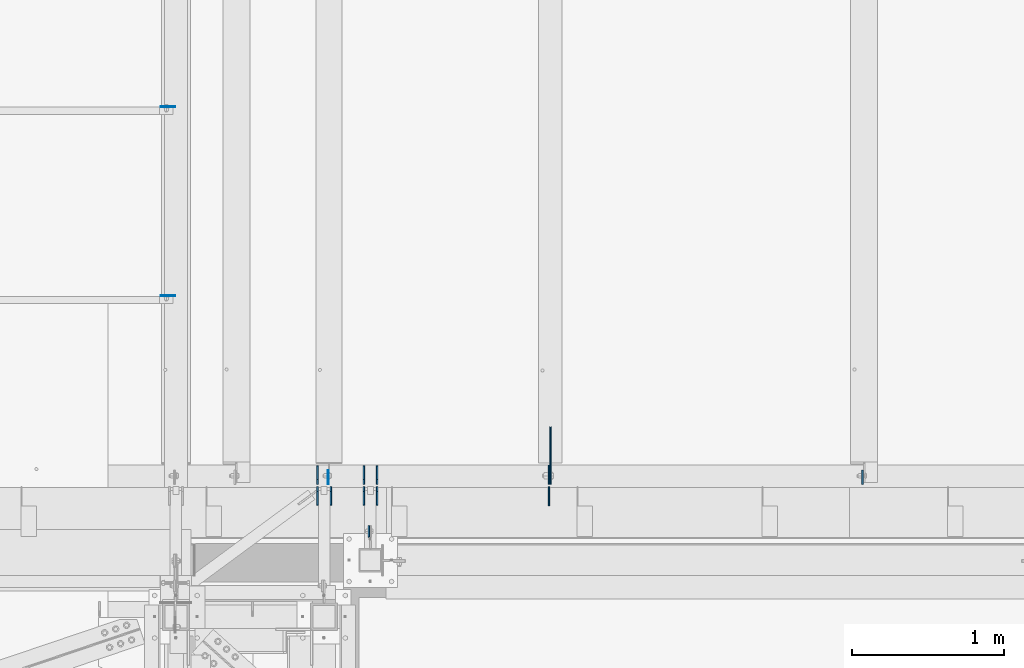
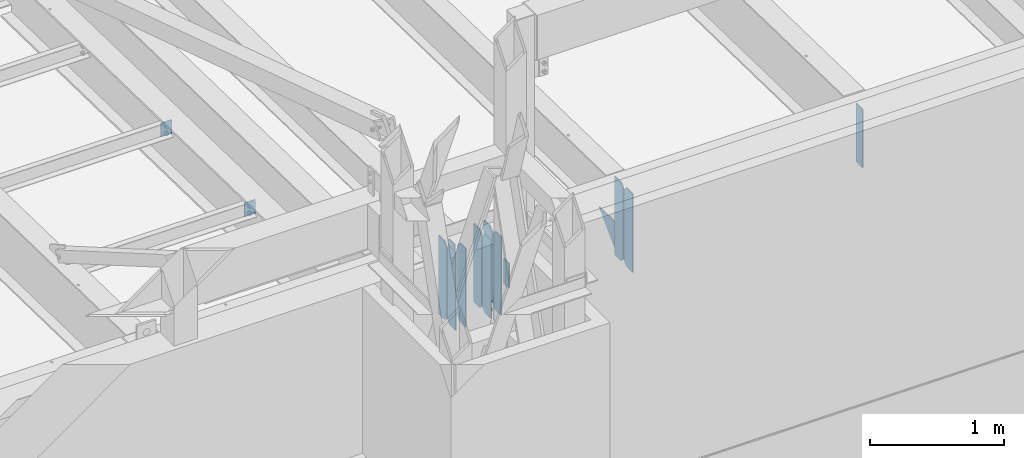
# One storey, part 1482 of 1763: 15 plates, 4 elements without a shape of their own.
"""IFC2X3 building model written with IfcOpenShell, lengths in millimetres."""

from ifc_helpers import new_model, si_unit, frame, origin_with_axes, place, context, subcontext, project, spatial, faceted_brep, material, type_object, element, aggregate, save


model = new_model("IFC2X3")

# Units and contexts
model_context = context("Model", 3, precision=1e-05, world=origin_with_axes())
body_context = subcontext(model_context, "Body", "Model", "MODEL_VIEW")
ifc_project = project(units=[si_unit("LENGTHUNIT", "METRE", prefix="MILLI"), si_unit("AREAUNIT", "SQUARE_METRE"), si_unit("VOLUMEUNIT", "CUBIC_METRE"), si_unit("MASSUNIT", "GRAM", prefix="KILO"), si_unit("TIMEUNIT", "SECOND"), si_unit("PLANEANGLEUNIT", "RADIAN"), si_unit("SOLIDANGLEUNIT", "STERADIAN"), si_unit("THERMODYNAMICTEMPERATUREUNIT", "DEGREE_CELSIUS"), si_unit("LUMINOUSINTENSITYUNIT", "LUMEN")], contexts=[model_context])

# Site, building, storey
site_placement = place(None, origin_with_axes())
site = spatial("IfcSite", under=ifc_project, at=site_placement, CompositionType="ELEMENT")
building_placement = place(site_placement, origin_with_axes())
building = spatial("IfcBuilding", under=site, at=building_placement, Name="Undefined", CompositionType="ELEMENT")
storey_placement = place(building_placement, origin_with_axes())
storey = spatial("IfcBuildingStorey", under=building, at=storey_placement, Name="Undefined", CompositionType="ELEMENT", Elevation=0.0)

# Assembly, plate
assembly_1_placement = place(storey_placement, origin_with_axes())
assembly_1 = element("IfcElementAssembly", 1, at=assembly_1_placement, inside=storey, Name="BEAM", AssemblyPlace="NOTDEFINED", PredefinedType="RIGID_FRAME")
ifc_material = material(Name="STEEL/A36")
plate_type_1 = type_object("IfcPlateType", PredefinedType="NOTDEFINED")
plate_1_placement = place(assembly_1_placement, frame((-46465.980404356, -14055.7264648314, 11858.625), z_axis=(0.0, 0.0, 1.0), x_axis=(0.0, 1.0, 0.0)))
plate_1 = element("IfcPlate", 2, at=plate_1_placement, type_object=plate_type_1, material=ifc_material, Name="PLATE", context=body_context, shape_type="Brep", body=[
    faceted_brep([(0.0, -4.76249999999982, 0.0), (-2.83762346953154e-10, -4.7624999996915, 228.600006103516), (-2.83762346953154e-10, 4.76250000028813, 228.600006103517), (0.0, 4.76249999999982, 0.0), (76.1999969480166, -4.76249999961874, 228.600006103516), (76.1999969480166, 4.76250000036089, 228.600006103517), (76.1999969482931, -4.76249999991705, 0.0), (76.1999969482931, 4.76250000006257, 1.81898940354586e-12)], [[[0, 1, 2, 3]], [[1, 4, 5, 2]], [[4, 6, 7, 5]], [[6, 0, 3, 7]], [[5, 7, 3, 2]], [[6, 4, 1, 0]]]),
])
aggregate(assembly_1, [plate_1])

# Assembly, plates
assembly_2_placement = place(storey_placement, origin_with_axes())
assembly_2 = element("IfcElementAssembly", 3, at=assembly_2_placement, inside=storey, Name="BEAM", AssemblyPlace="NOTDEFINED", PredefinedType="RIGID_FRAME")
plate_type_2 = type_object("IfcPlateType", PredefinedType="NOTDEFINED")
plate_2_placement = place(assembly_2_placement, frame((-46412.0055979689, -13844.5873186171, 11463.3375), z_axis=(0.0, 0.0, 1.0), x_axis=(0.0, 1.0, 0.0)))
plate_2 = element("IfcPlate", 4, at=plate_2_placement, type_object=plate_type_2, material=ifc_material, Name="PLATE", context=body_context, shape_type="Brep", body=[
    faceted_brep([(0.0, -4.76249999999982, 0.0), (0.0, -4.76249999999709, 714.375), (0.0, 4.76249999999709, 714.375), (0.0, 4.76249999999982, 0.0), (88.9000015258789, -4.76249999999709, 714.375), (88.9000015258789, 4.76249999999709, 714.375), (120.650001525879, -4.76249999999709, 682.625), (120.650001525879, 4.76249999999709, 682.625), (120.650001525879, -4.76249999999709, 31.75), (120.650001525879, 4.76249999999709, 31.75), (88.9000015258789, -4.76249999999709, 0.0), (88.9000015258789, 4.76249999999709, 0.0)], [[[0, 1, 2, 3]], [[1, 4, 5, 2]], [[4, 6, 7, 5]], [[6, 8, 9, 7]], [[8, 10, 11, 9]], [[10, 0, 3, 11]], [[5, 7, 9, 11, 3, 2]], [[10, 8, 6, 4, 1, 0]]]),
])
plate_3_placement = place(assembly_2_placement, frame((-46412.0055979689, -13708.0623186171, 11463.3375), z_axis=(0.0, 0.0, 1.0), x_axis=(0.0, 1.0, 0.0)))
plate_3 = element("IfcPlate", 5, at=plate_3_placement, type_object=plate_type_2, material=ifc_material, Name="PLATE", context=body_context, shape_type="Brep", body=[
    faceted_brep([(0.0, -4.76250000000073, 31.75), (0.0, -4.76249999999709, 682.625), (0.0, 4.76249999999709, 682.625), (0.0, 4.76250000000073, 31.75), (31.75, -4.76249999999709, 714.375), (31.75, 4.76249999999709, 714.375), (120.650001525879, -4.76249999999709, 714.375), (120.650001525879, 4.76249999999709, 714.375), (120.650001525879, -4.76249999999709, 0.0), (120.650001525879, 4.76249999999709, 0.0), (31.75, -4.76250000000073, 0.0), (31.75, 4.76250000000073, 0.0)], [[[0, 1, 2, 3]], [[1, 4, 5, 2]], [[4, 6, 7, 5]], [[6, 8, 9, 7]], [[8, 10, 11, 9]], [[10, 0, 3, 11]], [[5, 7, 9, 11, 3, 2]], [[10, 8, 6, 4, 1, 0]]]),
])
plate_4_placement = place(assembly_2_placement, frame((-46499.3180979689, -13844.5873186171, 11463.3375), z_axis=(0.0, 0.0, 1.0), x_axis=(0.0, 1.0, 0.0)))
plate_4 = element("IfcPlate", 6, at=plate_4_placement, type_object=plate_type_2, material=ifc_material, Name="PLATE", context=body_context, shape_type="Brep", body=[
    faceted_brep([(0.0, -4.76249999999982, 0.0), (0.0, -4.76249999999709, 714.375), (0.0, 4.76249999999709, 714.375), (0.0, 4.76249999999982, 0.0), (88.9000015258789, -4.76249999999709, 714.375), (88.9000015258789, 4.76249999999709, 714.375), (120.650001525879, -4.76249999999709, 682.625), (120.650001525879, 4.76249999999709, 682.625), (120.650001525879, -4.76249999999709, 31.75), (120.650001525879, 4.76249999999709, 31.75), (88.9000015258789, -4.76249999999709, 0.0), (88.9000015258789, 4.76249999999709, 0.0)], [[[0, 1, 2, 3]], [[1, 4, 5, 2]], [[4, 6, 7, 5]], [[6, 8, 9, 7]], [[8, 10, 11, 9]], [[10, 0, 3, 11]], [[5, 7, 9, 11, 3, 2]], [[10, 8, 6, 4, 1, 0]]]),
])
plate_5_placement = place(assembly_2_placement, frame((-46499.3180979689, -13708.0623186171, 11463.3375), z_axis=(0.0, 0.0, 1.0), x_axis=(0.0, 1.0, 0.0)))
plate_5 = element("IfcPlate", 7, at=plate_5_placement, type_object=plate_type_2, material=ifc_material, Name="PLATE", context=body_context, shape_type="Brep", body=[
    faceted_brep([(0.0, -4.76250000000073, 31.75), (0.0, -4.76249999999709, 682.625), (0.0, 4.76249999999709, 682.625), (0.0, 4.76250000000073, 31.75), (31.75, -4.76249999999709, 714.375), (31.75, 4.76249999999709, 714.375), (120.650001525879, -4.76249999999709, 714.375), (120.650001525879, 4.76249999999709, 714.375), (120.650001525879, -4.76249999999709, 0.0), (120.650001525879, 4.76249999999709, 0.0), (31.75, -4.76250000000073, 0.0), (31.75, 4.76250000000073, 0.0)], [[[0, 1, 2, 3]], [[1, 4, 5, 2]], [[4, 6, 7, 5]], [[6, 8, 9, 7]], [[8, 10, 11, 9]], [[10, 0, 3, 11]], [[5, 7, 9, 11, 3, 2]], [[10, 8, 6, 4, 1, 0]]]),
])
plate_6_placement = place(assembly_2_placement, frame((-46803.6897044142, -13844.5873186171, 11463.3375), z_axis=(0.0, 0.0, 1.0), x_axis=(0.0, 1.0, 0.0)))
plate_6 = element("IfcPlate", 8, at=plate_6_placement, type_object=plate_type_2, material=ifc_material, Name="PLATE", context=body_context, shape_type="Brep", body=[
    faceted_brep([(0.0, -4.76249999999982, 0.0), (0.0, -4.76249999999709, 714.375), (0.0, 4.76249999999709, 714.375), (0.0, 4.76249999999982, 0.0), (88.9000015258789, -4.76249999999709, 714.375), (88.9000015258789, 4.76249999999709, 714.375), (120.650001525879, -4.76249999999709, 682.625), (120.650001525879, 4.76249999999709, 682.625), (120.650001525879, -4.76249999999709, 31.75), (120.650001525879, 4.76249999999709, 31.75), (88.9000015258789, -4.76249999999709, 0.0), (88.9000015258789, 4.76249999999709, 0.0)], [[[0, 1, 2, 3]], [[1, 4, 5, 2]], [[4, 6, 7, 5]], [[6, 8, 9, 7]], [[8, 10, 11, 9]], [[10, 0, 3, 11]], [[5, 7, 9, 11, 3, 2]], [[10, 8, 6, 4, 1, 0]]]),
])
plate_7_placement = place(assembly_2_placement, frame((-46716.3772044142, -13844.5873186171, 11463.3375), z_axis=(0.0, 0.0, 1.0), x_axis=(0.0, 1.0, 0.0)))
plate_7 = element("IfcPlate", 9, at=plate_7_placement, type_object=plate_type_2, material=ifc_material, Name="PLATE", context=body_context, shape_type="Brep", body=[
    faceted_brep([(0.0, -4.76249999999982, 0.0), (0.0, -4.76249999999709, 714.375), (0.0, 4.76249999999709, 714.375), (0.0, 4.76249999999982, 0.0), (88.9000015258789, -4.76249999999709, 714.375), (88.9000015258789, 4.76249999999709, 714.375), (120.650001525879, -4.76249999999709, 682.625), (120.650001525879, 4.76249999999709, 682.625), (120.650001525879, -4.76249999999709, 31.75), (120.650001525879, 4.76249999999709, 31.75), (88.9000015258789, -4.76249999999709, 0.0), (88.9000015258789, 4.76249999999709, 0.0)], [[[0, 1, 2, 3]], [[1, 4, 5, 2]], [[4, 6, 7, 5]], [[6, 8, 9, 7]], [[8, 10, 11, 9]], [[10, 0, 3, 11]], [[5, 7, 9, 11, 3, 2]], [[10, 8, 6, 4, 1, 0]]]),
])
plate_8_placement = place(assembly_2_placement, frame((-46803.6897044142, -13708.0623186171, 11463.3375), z_axis=(0.0, 0.0, 1.0), x_axis=(0.0, 1.0, 0.0)))
plate_8 = element("IfcPlate", 10, at=plate_8_placement, type_object=plate_type_2, material=ifc_material, Name="PLATE", context=body_context, shape_type="Brep", body=[
    faceted_brep([(0.0, -4.76250000000073, 31.75), (0.0, -4.76249999999709, 682.625), (0.0, 4.76249999999709, 682.625), (0.0, 4.76250000000073, 31.75), (31.75, -4.76249999999709, 714.375), (31.75, 4.76249999999709, 714.375), (120.650001525879, -4.76249999999709, 714.375), (120.650001525879, 4.76249999999709, 714.375), (120.650001525879, -4.76249999999709, 0.0), (120.650001525879, 4.76249999999709, 0.0), (31.75, -4.76250000000073, 0.0), (31.75, 4.76250000000073, 0.0)], [[[0, 1, 2, 3]], [[1, 4, 5, 2]], [[4, 6, 7, 5]], [[6, 8, 9, 7]], [[8, 10, 11, 9]], [[10, 0, 3, 11]], [[5, 7, 9, 11, 3, 2]], [[10, 8, 6, 4, 1, 0]]]),
])

assembly_3_placement = place(storey_placement, origin_with_axes())
assembly_3 = element("IfcElementAssembly", 11, at=assembly_3_placement, inside=storey, Name="BEAM", AssemblyPlace="NOTDEFINED", PredefinedType="RIGID_FRAME")
plate_type_3 = type_object("IfcPlateType", PredefinedType="NOTDEFINED")
plate_9_placement = place(assembly_3_placement, frame((-47741.1197459181, -11224.4126198456, 12127.2773623981), z_axis=(-1.0, 0.0, 0.0), x_axis=(0.0, 0.0, -1.0)))
plate_9 = element("IfcPlate", 12, at=plate_9_placement, type_object=plate_type_3, material=ifc_material, Name="PLATE", context=body_context, shape_type="Brep", body=[
    faceted_brep([(1.81898940354586e-12, -3.17500000000291, 0.0), (0.0, -3.17499999999927, 95.25), (0.0, 3.17499999999927, 95.25), (-1.81898940354586e-12, 3.17499999997381, 0.0), (127.0, -3.17499999999927, 95.25), (127.0, 3.17499999999927, 95.25), (127.0, -3.17499999999927, 0.0), (127.0, 3.17499999999927, 0.0)], [[[0, 1, 2, 3]], [[1, 4, 5, 2]], [[4, 6, 7, 5]], [[6, 0, 3, 7]], [[5, 7, 3, 2]], [[6, 4, 1, 0]]]),
])
plate_10_placement = place(assembly_3_placement, frame((-47741.1197459181, -12468.6187192313, 12153.2886368763), z_axis=(-1.0, 0.0, 0.0), x_axis=(0.0, 0.0, -1.0)))
plate_10 = element("IfcPlate", 13, at=plate_10_placement, type_object=plate_type_3, material=ifc_material, Name="PLATE", context=body_context, shape_type="Brep", body=[
    faceted_brep([(1.81898940354586e-12, -3.17500000000291, 0.0), (0.0, -3.17499999999927, 95.25), (0.0, 3.17499999999927, 95.25), (-1.81898940354586e-12, 3.17499999997381, 0.0), (127.0, -3.17499999999927, 95.25), (127.0, 3.17499999999927, 95.25), (127.0, -3.17499999999927, 0.0), (127.0, 3.17499999999927, 0.0)], [[[0, 1, 2, 3]], [[1, 4, 5, 2]], [[4, 6, 7, 5]], [[6, 0, 3, 7]], [[5, 7, 3, 2]], [[6, 4, 1, 0]]]),
])
aggregate(assembly_3, [plate_9, plate_10])

# Plate
plate_type_4 = type_object("IfcPlateType", PredefinedType="NOTDEFINED")
plate_11_placement = place(assembly_2_placement, frame((-46734.5301308412, -13708.0623186171, 12141.4381106629), z_axis=(0.0, 1.0, 0.0), x_axis=(0.0, 0.0, -1.0)))
plate_11 = element("IfcPlate", 14, at=plate_11_placement, type_object=plate_type_4, material=ifc_material, Name="PLATE", context=body_context, shape_type="Brep", body=[
    faceted_brep([(1.81898940354586e-12, -3.17500000000291, 0.0), (0.0, -3.17499999999927, 93.6624984741211), (0.0, 3.17499999999927, 93.6624984741211), (-1.81898940354586e-12, 3.17499999997381, 0.0), (228.600006103516, -3.17499999999927, 93.6624984741211), (228.600006103516, 3.17499999999927, 93.6624984741211), (228.600006103516, -3.17500000001019, -7.27595761418343e-12), (228.600006103516, 3.17499999999563, -7.27595761418343e-12)], [[[0, 1, 2, 3]], [[1, 4, 5, 2]], [[4, 6, 7, 5]], [[6, 0, 3, 7]], [[5, 7, 3, 2]], [[6, 4, 1, 0]]]),
])

plate_type_5 = type_object("IfcPlateType", PredefinedType="NOTDEFINED")
plate_12_placement = place(assembly_2_placement, frame((-45281.0614880489, -13723.9373186171, 11461.75), z_axis=(0.0, 0.0, 1.0), x_axis=(0.0, -1.0, 0.0)))
plate_12 = element("IfcPlate", 15, at=plate_12_placement, type_object=plate_type_5, material=ifc_material, Name="PLATE", context=body_context, shape_type="Brep", body=[
    faceted_brep([(0.0, -3.96899999999732, 31.75), (0.0, -3.96899999999732, 685.799987792969), (0.0, 3.96899999999732, 685.799987792969), (0.0, 3.96899999999732, 31.75), (31.75, -3.96899999999732, 717.549987792969), (31.75, 3.96899999999732, 717.549987792969), (125.412498474121, -3.96899999999732, 717.549987792969), (125.412498474121, 3.96899999999732, 717.549987792969), (125.412506103516, -3.96899999999732, 0.0), (125.412506103516, 3.96899999999732, 0.0), (31.75, -3.96899999999732, 0.0), (31.75, 3.96899999999732, 0.0)], [[[0, 1, 2, 3]], [[1, 4, 5, 2]], [[4, 6, 7, 5]], [[6, 8, 9, 7]], [[8, 10, 11, 9]], [[10, 0, 3, 11]], [[5, 7, 9, 11, 3, 2]], [[10, 8, 6, 4, 1, 0]]]),
])

plate_13_placement = place(assembly_2_placement, frame((-45281.0614880489, -13708.0623186171, 11463.3375), z_axis=(0.0, 0.0, 1.0), x_axis=(0.0, 1.0, 0.0)))
plate_13 = element("IfcPlate", 16, at=plate_13_placement, type_object=plate_type_5, material=ifc_material, Name="PLATE", context=body_context, shape_type="Brep", body=[
    faceted_brep([(0.0, -3.96899999999732, 31.75), (0.0, -3.96900000000096, 684.212524414062), (0.0, 3.96900000000096, 684.212524414062), (0.0, 3.96899999999732, 31.75), (31.75, -3.96900000000096, 715.962524414062), (31.75, 3.96900000000096, 715.962524414062), (125.412498474121, -3.96899999999732, 715.962524414062), (125.412498474121, 3.96899999999732, 715.962524414062), (125.412506103516, -3.96899999999732, 0.0), (125.412506103516, 3.96899999999732, 0.0), (31.75, -3.96899999999732, 0.0), (31.75, 3.96899999999732, 0.0)], [[[0, 1, 2, 3]], [[1, 4, 5, 2]], [[4, 6, 7, 5]], [[6, 8, 9, 7]], [[8, 10, 11, 9]], [[10, 0, 3, 11]], [[5, 7, 9, 11, 3, 2]], [[10, 8, 6, 4, 1, 0]]]),
])

# Assembly, plate
assembly_4_placement = place(storey_placement, origin_with_axes())
assembly_4 = element("IfcElementAssembly", 17, at=assembly_4_placement, inside=storey, Name="BEAM", AssemblyPlace="NOTDEFINED", PredefinedType="RIGID_FRAME")
plate_type_6 = type_object("IfcPlateType", PredefinedType="NOTDEFINED")
plate_14_placement = place(assembly_4_placement, frame((-45271.5364880489, -13708.0623186171, 11493.7197571539), z_axis=(0.0, 0.0, 1.0), x_axis=(0.0, 1.0, 0.0)))
plate_14 = element("IfcPlate", 18, at=plate_14_placement, type_object=plate_type_6, material=ifc_material, Name="PLATE", context=body_context, shape_type="Brep", body=[
    faceted_brep([(0.0, -4.76249999999982, 0.0), (0.0, -4.76249999999709, 259.865783691406), (0.0, 4.76249999999709, 259.865783691406), (0.0, 4.76249999999982, 0.0), (377.890502929688, -4.76249999999709, 251.96614074707), (377.890502929688, 4.76249999999709, 251.96614074707), (125.412498474121, -4.76249999999709, 0.0), (125.412498474121, 4.76249999999709, 0.0)], [[[0, 1, 2, 3]], [[1, 4, 5, 2]], [[4, 6, 7, 5]], [[6, 0, 3, 7]], [[5, 7, 3, 2]], [[6, 4, 1, 0]]]),
])
aggregate(assembly_4, [plate_14])

# Plate
plate_type_7 = type_object("IfcPlateType", PredefinedType="NOTDEFINED")
plate_15_placement = place(assembly_2_placement, frame((-43217.9908451269, -13708.0623186171, 12141.4381181097), z_axis=(0.0, 1.0, 0.0), x_axis=(0.0, 0.0, -1.0)))
plate_15 = element("IfcPlate", 19, at=plate_15_placement, type_object=plate_type_7, material=ifc_material, Name="PLATE", context=body_context, shape_type="Brep", body=[
    faceted_brep([(0.0, -4.76249999999982, 0.0), (0.0, -4.76249999999709, 93.6624984741211), (0.0, 4.76249999999709, 93.6624984741211), (0.0, 4.76249999999982, 0.0), (533.400024414062, -4.76249999999709, 93.6624984741211), (533.400024414062, 4.76249999999709, 93.6624984741211), (533.400024414062, -4.76250000000073, 0.0), (533.400024414062, 4.76250000000073, 0.0)], [[[0, 1, 2, 3]], [[1, 4, 5, 2]], [[4, 6, 7, 5]], [[6, 0, 3, 7]], [[5, 7, 3, 2]], [[6, 4, 1, 0]]]),
])

aggregate(assembly_2, [plate_11, plate_2, plate_3, plate_4, plate_5, plate_6, plate_7, plate_8, plate_15, plate_12, plate_13])

save(model, "model.ifc")
